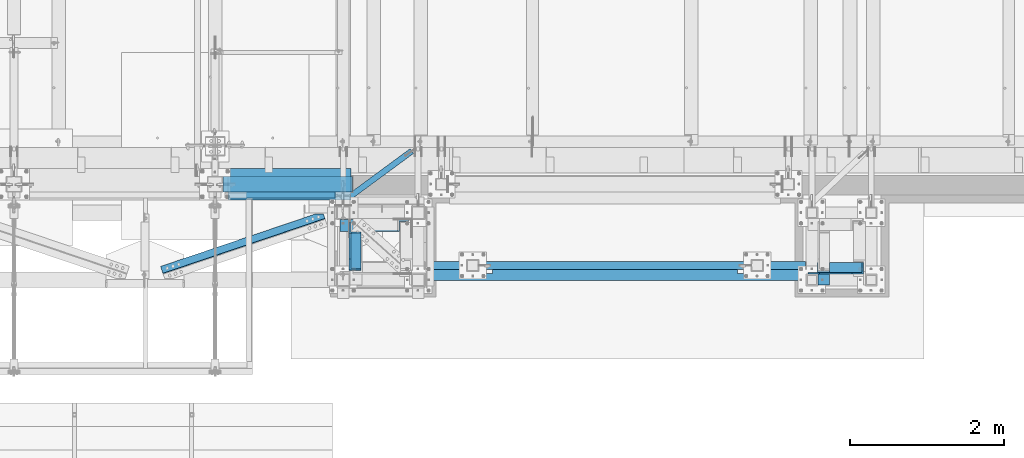
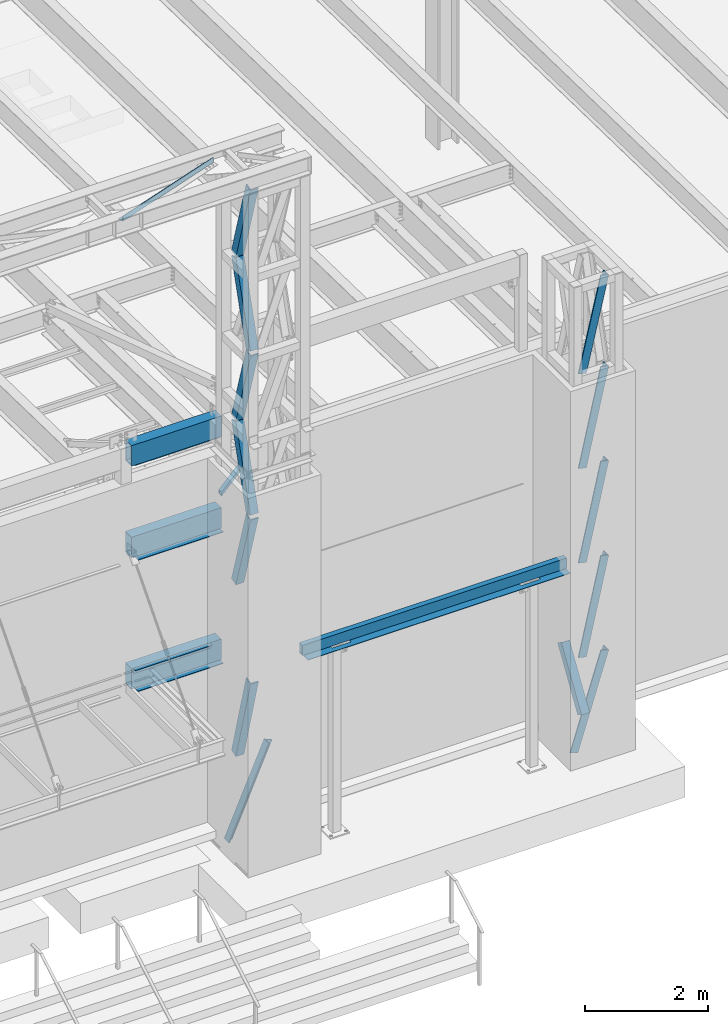
# One storey, part 1062 of 1763: 13 members, 11 beams, 8 elements without a shape of their own.
"""IFC2X3 building model written with IfcOpenShell, lengths in millimetres."""

from ifc_helpers import new_model, si_unit, frame, origin_with_axes, place, context, subcontext, project, spatial, faceted_brep, material, type_object, element, aggregate, save


model = new_model("IFC2X3")

# Units and contexts
model_context = context("Model", 3, precision=1e-05, world=origin_with_axes())
body_context = subcontext(model_context, "Body", "Model", "MODEL_VIEW")
ifc_project = project(units=[si_unit("LENGTHUNIT", "METRE", prefix="MILLI"), si_unit("AREAUNIT", "SQUARE_METRE"), si_unit("VOLUMEUNIT", "CUBIC_METRE"), si_unit("MASSUNIT", "GRAM", prefix="KILO"), si_unit("TIMEUNIT", "SECOND"), si_unit("PLANEANGLEUNIT", "RADIAN"), si_unit("SOLIDANGLEUNIT", "STERADIAN"), si_unit("THERMODYNAMICTEMPERATUREUNIT", "DEGREE_CELSIUS"), si_unit("LUMINOUSINTENSITYUNIT", "LUMEN")], contexts=[model_context])

# Site, building, storey
site_placement = place(None, origin_with_axes())
site = spatial("IfcSite", under=ifc_project, at=site_placement, CompositionType="ELEMENT")
building_placement = place(site_placement, origin_with_axes())
building = spatial("IfcBuilding", under=site, at=building_placement, Name="Undefined", CompositionType="ELEMENT")
storey_placement = place(building_placement, origin_with_axes())
storey = spatial("IfcBuildingStorey", under=building, at=storey_placement, Name="Undefined", CompositionType="ELEMENT", Elevation=0.0)

# Assembly, members
assembly_1_placement = place(storey_placement, origin_with_axes())
assembly_1 = element("IfcElementAssembly", 1, at=assembly_1_placement, inside=storey, Name="FRAME", AssemblyPlace="NOTDEFINED", PredefinedType="RIGID_FRAME")
ifc_material_1 = material(Name="STEEL/A36")
member_type = type_object("IfcMemberType", Name="L6X6X7/8", PredefinedType="NOTDEFINED")
member_1_placement = place(assembly_1_placement, frame((-41487.0960743714, -14799.7440466846, 6945.69763129711), z_axis=(-1.90000006114133e-07, 0.846976442016007, -0.531630423010074), x_axis=(1.18999999498545e-07, -0.53163042301006, -0.846976442016028)))
member_1 = element("IfcMember", 2, at=member_1_placement, type_object=member_type, material=ifc_material_1, Name="V. BRACE", ObjectType="L6X6X7/8", context=body_context, shape_type="Brep", body=[
    faceted_brep([(9.09494701772928e-13, -76.2000000000007, -76.2000000000844), (9.09494701772928e-13, 76.2000000000007, -76.2000000000844), (1228.13053531922, 76.1999999928375, -76.2000000008793), (1228.1305353191, -76.2000000071712, -76.2000000007974), (1.81898940354586e-12, -76.2000000000007, -53.9750000000604), (1.81898940354586e-12, 53.9750000000004, -53.9750000000604), (0.0, 53.9750000000004, 76.2000000000771), (0.0, 76.2000000000007, 76.2000000000771), (1228.13053531911, -76.2000000070693, -53.9750000008135), (1228.13053531921, 53.9749999929481, -53.9750000008862), (1228.13053531927, 53.9749999934866, 76.1999999990185), (1228.13053531929, 76.1999999934924, 76.1999999990057)], [[[0, 1, 2, 3]], [[0, 4, 5, 6, 7, 1]], [[5, 4, 8, 9]], [[6, 5, 9, 10]], [[7, 6, 10, 11]], [[1, 7, 11, 2]], [[10, 9, 8, 3, 2, 11]], [[4, 0, 3, 8]]]),
])
member_2_placement = place(assembly_1_placement, frame((-41043.7895703936, -15300.3943970326, 12588.8749998544), z_axis=(-0.975768660920604, 0.0, 0.218804753982199), x_axis=(-0.218804753982199, 0.0, -0.975768660920604)))
member_2 = element("IfcMember", 3, at=member_2_placement, type_object=member_type, material=ifc_material_1, Name="V. BRACE", ObjectType="L6X6X7/8", context=body_context, shape_type="Brep", body=[
    faceted_brep([(9.09494701772928e-13, 76.2000000000007, -76.2000000000844), (0.0, 76.2000000000007, 76.2000000000771), (1920.5820240066, 76.2000000000007, 76.1999999998516), (1920.58202400652, 76.2000000000007, -76.2000000004628), (0.0, 53.9750000000004, 76.2000000000771), (1920.5820240066, 53.9750000000004, 76.1999999998516), (1.81898940354586e-12, 53.9750000000004, -53.9750000000604), (1920.58202400653, 53.9750000000004, -53.9750000004133), (1.81898940354586e-12, -76.2000000000007, -53.9750000000604), (1920.58202400653, -76.2000000000007, -53.9750000004133), (9.09494701772928e-13, -76.2000000000007, -76.2000000000844), (1920.58202400652, -76.2000000000007, -76.2000000004628)], [[[0, 1, 2, 3]], [[1, 4, 5, 2]], [[4, 6, 7, 5]], [[6, 8, 9, 7]], [[8, 10, 11, 9]], [[10, 0, 3, 11]], [[5, 7, 9, 11, 3, 2]], [[10, 8, 6, 4, 1, 0]]]),
])
member_3_placement = place(assembly_1_placement, frame((-41043.7895703902, -15300.3943970326, 10714.8312498544), z_axis=(-0.975768660920604, 0.0, 0.218804753982199), x_axis=(-0.218804753982199, 0.0, -0.975768660920604)))
member_3 = element("IfcMember", 4, at=member_3_placement, type_object=member_type, material=ifc_material_1, Name="V. BRACE", ObjectType="L6X6X7/8", context=body_context, shape_type="Brep", body=[
    faceted_brep([(9.09494701772928e-13, 76.2000000000007, -76.2000000000844), (0.0, 76.2000000000007, 76.2000000000771), (1920.5820240066, 76.2000000000007, 76.1999999998516), (1920.58202400652, 76.2000000000007, -76.2000000004628), (0.0, 53.9750000000004, 76.2000000000771), (1920.5820240066, 53.9750000000004, 76.1999999998516), (1.81898940354586e-12, 53.9750000000004, -53.9750000000604), (1920.58202400653, 53.9750000000004, -53.9750000004133), (1.81898940354586e-12, -76.2000000000007, -53.9750000000604), (1920.58202400653, -76.2000000000007, -53.9750000004133), (9.09494701772928e-13, -76.2000000000007, -76.2000000000844), (1920.58202400652, -76.2000000000007, -76.2000000004628)], [[[0, 1, 2, 3]], [[1, 4, 5, 2]], [[4, 6, 7, 5]], [[6, 8, 9, 7]], [[8, 10, 11, 9]], [[10, 0, 3, 11]], [[5, 7, 9, 11, 3, 2]], [[10, 8, 6, 4, 1, 0]]]),
])
member_4_placement = place(assembly_1_placement, frame((-41043.6534532062, -15300.3943970326, 14401.8000002035), z_axis=(-0.974137606436103, 0.0, 0.225955579101161), x_axis=(-0.225955579101159, 0.0, -0.974137606436103)))
member_4 = element("IfcMember", 5, at=member_4_placement, type_object=member_type, material=ifc_material_1, Name="V. BRACE", ObjectType="L6X6X7/8", context=body_context, shape_type="Brep", body=[
    faceted_brep([(9.09494701772928e-13, 76.2000000000007, -76.2000000000844), (0.0, 76.2000000000007, 76.2000000000771), (1861.05637242494, 76.2000000000007, 76.1999999891268), (1861.05637242493, 76.2000000000007, -76.2000000105327), (0.0, 53.9750000000004, 76.2000000000771), (1861.05637242494, 53.9750000000004, 76.1999999891268), (1.81898940354586e-12, 53.9750000000004, -53.9750000000604), (1861.05637242493, 53.9750000000004, -53.9750000105851), (1.81898940354586e-12, -76.2000000000007, -53.9750000000604), (1861.05637242493, -76.2000000000007, -53.9750000105851), (9.09494701772928e-13, -76.2000000000007, -76.2000000000844), (1861.05637242493, -76.2000000000007, -76.2000000105327)], [[[0, 1, 2, 3]], [[1, 4, 5, 2]], [[4, 6, 7, 5]], [[6, 8, 9, 7]], [[8, 10, 11, 9]], [[10, 0, 3, 11]], [[5, 7, 9, 11, 3, 2]], [[10, 8, 6, 4, 1, 0]]]),
])
member_5_placement = place(assembly_1_placement, frame((-41043.7895703868, -15300.3943970326, 8840.7874998544), z_axis=(-0.975768660920604, 0.0, 0.218804753982199), x_axis=(-0.218804753982199, 0.0, -0.975768660920604)))
member_5 = element("IfcMember", 6, at=member_5_placement, type_object=member_type, material=ifc_material_1, Name="V. BRACE", ObjectType="L6X6X7/8", context=body_context, shape_type="Brep", body=[
    faceted_brep([(9.09494701772928e-13, 76.2000000000007, -76.2000000000844), (0.0, 76.2000000000007, 76.2000000000771), (1920.5820240066, 76.2000000000007, 76.1999999998516), (1920.58202400652, 76.2000000000007, -76.2000000004628), (0.0, 53.9750000000004, 76.2000000000771), (1920.5820240066, 53.9750000000004, 76.1999999998516), (1.81898940354586e-12, 53.9750000000004, -53.9750000000604), (1920.58202400653, 53.9750000000004, -53.9750000004133), (1.81898940354586e-12, -76.2000000000007, -53.9750000000604), (1920.58202400653, -76.2000000000007, -53.9750000004133), (9.09494701772928e-13, -76.2000000000007, -76.2000000000844), (1920.58202400652, -76.2000000000007, -76.2000000004628)], [[[0, 1, 2, 3]], [[1, 4, 5, 2]], [[4, 6, 7, 5]], [[6, 8, 9, 7]], [[8, 10, 11, 9]], [[10, 0, 3, 11]], [[5, 7, 9, 11, 3, 2]], [[10, 8, 6, 4, 1, 0]]]),
])
member_6_placement = place(assembly_1_placement, frame((-41042.0722853274, -15300.3943970326, 6966.74375009387), z_axis=(-0.953918533796507, 0.0, 0.300065710935991), x_axis=(-0.300065710935989, 0.0, -0.953918533796508)))
member_6 = element("IfcMember", 7, at=member_6_placement, type_object=member_type, material=ifc_material_1, Name="V. BRACE", ObjectType="L6X6X7/8", context=body_context, shape_type="Brep", body=[
    faceted_brep([(9.09494701772928e-13, 76.2000000000007, -76.2000000000844), (0.0, 76.2000000000007, 76.2000000000771), (1927.29114476475, 76.2000000000007, 76.2000000015396), (1927.29114476478, 76.2000000000007, -76.1999999978871), (0.0, 53.9750000000004, 76.2000000000771), (1927.29114476475, 53.9750000000004, 76.2000000015396), (1.81898940354586e-12, 53.9750000000004, -53.9750000000604), (1927.29114476478, 53.9750000000004, -53.974999997954), (1.81898940354586e-12, -76.2000000000007, -53.9750000000604), (1927.29114476478, -76.2000000000007, -53.974999997954), (9.09494701772928e-13, -76.2000000000007, -76.2000000000844), (1927.29114476478, -76.2000000000007, -76.1999999978871)], [[[0, 1, 2, 3]], [[1, 4, 5, 2]], [[4, 6, 7, 5]], [[6, 8, 9, 7]], [[8, 10, 11, 9]], [[10, 0, 3, 11]], [[5, 7, 9, 11, 3, 2]], [[10, 8, 6, 4, 1, 0]]]),
])
aggregate(assembly_1, [member_1, member_2, member_3, member_4, member_5, member_6])

assembly_2_placement = place(storey_placement, origin_with_axes())
assembly_2 = element("IfcElementAssembly", 8, at=assembly_2_placement, inside=storey, Name="FRAME", AssemblyPlace="NOTDEFINED", PredefinedType="RIGID_FRAME")
member_7_placement = place(assembly_2_placement, frame((-47735.5523704055, -14744.7029550285, 5067.29978345798), z_axis=(0.0, -1.0, 0.0), x_axis=(0.400955294202786, 1.00000025355767e-09, 0.916097621463323)))
member_7 = element("IfcMember", 9, at=member_7_placement, type_object=member_type, material=ifc_material_1, Name="V. BRACE", ObjectType="L6X6X7/8", context=body_context, shape_type="Brep", body=[
    faceted_brep([(74.9407141546053, 76.200000000179, -76.2000000000698), (74.9407141245028, 76.1999999999971, 76.1999999999316), (1940.84119258349, 76.2000000036787, 76.1999999991021), (1940.84119258334, 76.2000000038752, -76.2000000008975), (74.9407141244592, 53.9750000000131, 76.1999999999425), (1940.84119258348, 53.9750000036947, 76.1999999991149), (74.9407141501724, 53.9750000001732, -53.9750000000568), (1940.84119258335, 53.9750000038621, -53.9750000008862), (74.9407141499069, -76.1999999997206, -53.9749999999967), (1940.84119258335, -76.199999996039, -53.9750000008244), (74.9407141542943, -76.1999999996842, -76.1999999999953), (1940.84119258333, -76.1999999960099, -76.2000000008247)], [[[0, 1, 2, 3]], [[1, 4, 5, 2]], [[4, 6, 7, 5]], [[6, 8, 9, 7]], [[8, 10, 11, 9]], [[10, 0, 3, 11]], [[5, 7, 9, 11, 3, 2]], [[10, 8, 6, 4, 1, 0]]]),
])
member_8_placement = place(assembly_2_placement, frame((-47583.152204354, -14779.1376538228, 16774.1203120008), z_axis=(1.0, 0.0, 0.0), x_axis=(0.0, -0.28425468487658, 0.958748806583725)))
member_8 = element("IfcMember", 10, at=member_8_placement, type_object=member_type, material=ifc_material_1, Name="V. BRACE", ObjectType="L6X6X7/8", context=body_context, shape_type="Brep", body=[
    faceted_brep([(1.81898940354586e-12, -76.2000000000007, -53.9750000000604), (9.09494701772928e-13, -76.2000000000007, -76.2000000000844), (1668.42939139346, -76.2000000002827, -76.1999999999971), (1668.42939139346, -76.2000000002827, -53.9749999999985), (1.81898940354586e-12, 53.9750000000004, -53.9750000000604), (1668.42939139347, 53.9749999998239, -53.9749999999985), (0.0, 53.9750000000004, 76.2000000000771), (1668.42939139347, 53.9749999998239, 76.1999999999971), (0.0, 76.2000000000007, 76.2000000000771), (1668.42939139347, 76.1999999998425, 76.1999999999971), (9.09494701772928e-13, 76.2000000000007, -76.2000000000844), (1668.42939139347, 76.1999999998425, -76.1999999999971)], [[[0, 1, 2, 3]], [[4, 0, 3, 5]], [[6, 4, 5, 7]], [[8, 6, 7, 9]], [[1, 0, 4, 6, 8, 10]], [[1, 10, 11, 2]], [[7, 5, 3, 2, 11, 9]], [[10, 8, 9, 11]]]),
])
member_9_placement = place(assembly_2_placement, frame((-47583.1519986869, -14778.8696225472, 13524.110936), z_axis=(1.0, 0.0, 0.0), x_axis=(0.0, -0.2898381940609, 0.957075661201097)))
member_9 = element("IfcMember", 11, at=member_9_placement, type_object=member_type, material=ifc_material_1, Name="V. BRACE", ObjectType="L6X6X7/8", context=body_context, shape_type="Brep", body=[
    faceted_brep([(9.09494701772928e-13, 76.2000000000007, -76.2000000000844), (0.0, 76.2000000000007, 76.2000000000771), (1639.83084289621, 76.1999999999971, 76.1999999993677), (1639.83084289615, 76.1999999999971, -76.2000000006465), (0.0, 53.9750000000004, 76.2000000000771), (1639.83084289621, 53.9749999999985, 76.1999999993677), (1.81898940354586e-12, 53.9750000000004, -53.9750000000604), (1639.83084289616, 53.9749999999985, -53.9750000006443), (1.81898940354586e-12, -76.2000000000007, -53.9750000000604), (1639.83084289616, -76.1999999999971, -53.9750000006443), (9.09494701772928e-13, -76.2000000000007, -76.2000000000844), (1639.83084289615, -76.1999999999971, -76.2000000006465)], [[[0, 1, 2, 3]], [[1, 4, 5, 2]], [[4, 6, 7, 5]], [[6, 8, 9, 7]], [[8, 10, 11, 9]], [[10, 0, 3, 11]], [[5, 7, 9, 11, 3, 2]], [[10, 8, 6, 4, 1, 0]]]),
])
member_10_placement = place(assembly_2_placement, frame((-47583.1519986869, -15253.4500546581, 15149.115624), z_axis=(1.0, 0.0, 0.0), x_axis=(0.0, 0.289497082081885, 0.957178896270741)))
member_10 = element("IfcMember", 12, at=member_10_placement, type_object=member_type, material=ifc_material_1, Name="V. BRACE", ObjectType="L6X6X7/8", context=body_context, shape_type="Brep", body=[
    faceted_brep([(9.09494701772928e-13, 76.2000000000007, -76.2000000000844), (0.0, 76.2000000000007, 76.2000000000771), (1639.65398114875, 76.1999999994368, 76.1999999999971), (1639.65398114875, 76.1999999994368, -76.1999999999971), (0.0, 53.9750000000004, 76.2000000000771), (1639.65398114874, 53.9749999994274, 76.1999999999971), (1.81898940354586e-12, 53.9750000000004, -53.9750000000604), (1639.65398114874, 53.9749999994274, -53.9749999999985), (1.81898940354586e-12, -76.2000000000007, -53.9750000000604), (1639.6539811487, -76.2000000006228, -53.9749999999985), (9.09494701772928e-13, -76.2000000000007, -76.2000000000844), (1639.6539811487, -76.2000000006228, -76.1999999999971)], [[[0, 1, 2, 3]], [[1, 4, 5, 2]], [[4, 6, 7, 5]], [[6, 8, 9, 7]], [[8, 10, 11, 9]], [[10, 0, 3, 11]], [[5, 7, 9, 11, 3, 2]], [[10, 8, 6, 4, 1, 0]]]),
])
member_11_placement = place(assembly_2_placement, frame((-47583.4054377434, -14778.8361418315, 10274.101560012), z_axis=(0.999999857834454, 0.000533227035961318, -1.19036485557445e-10), x_axis=(0.000154551999968596, -0.28984251293782, 0.957074340794679)))
member_11 = element("IfcMember", 13, at=member_11_placement, type_object=member_type, material=ifc_material_1, Name="V. BRACE", ObjectType="L6X6X7/8", context=body_context, shape_type="Brep", body=[
    faceted_brep([(9.09494701772928e-13, 76.2000000000007, -76.2000000000844), (0.0, 76.2000000000007, 76.2000000000771), (1639.83084289621, 76.1999999999971, 76.1999999993677), (1639.83084289615, 76.1999999999971, -76.2000000006465), (0.0, 53.9750000000004, 76.2000000000771), (1639.83084289621, 53.9749999999985, 76.1999999993677), (1.81898940354586e-12, 53.9750000000004, -53.9750000000604), (1639.83084289616, 53.9749999999985, -53.9750000006443), (1.81898940354586e-12, -76.2000000000007, -53.9750000000604), (1639.83084289616, -76.1999999999971, -53.9750000006443), (9.09494701772928e-13, -76.2000000000007, -76.2000000000844), (1639.83084289615, -76.1999999999971, -76.2000000006465)], [[[0, 1, 2, 3]], [[1, 4, 5, 2]], [[4, 6, 7, 5]], [[6, 8, 9, 7]], [[8, 10, 11, 9]], [[10, 0, 3, 11]], [[5, 7, 9, 11, 3, 2]], [[10, 8, 6, 4, 1, 0]]]),
])
member_12_placement = place(assembly_2_placement, frame((-47583.1519986869, -15253.4580745193, 11899.106248), z_axis=(1.0, 0.0, 0.0), x_axis=(0.0, 0.289837226101388, 0.957075954334792)))
member_12 = element("IfcMember", 14, at=member_12_placement, type_object=member_type, material=ifc_material_1, Name="V. BRACE", ObjectType="L6X6X7/8", context=body_context, shape_type="Brep", body=[
    faceted_brep([(9.09494701772928e-13, 76.2000000000007, -76.2000000000844), (0.0, 76.2000000000007, 76.2000000000771), (1639.83084289621, 76.1999999999971, 76.1999999993677), (1639.83084289615, 76.1999999999971, -76.2000000006465), (0.0, 53.9750000000004, 76.2000000000771), (1639.83084289621, 53.9749999999985, 76.1999999993677), (1.81898940354586e-12, 53.9750000000004, -53.9750000000604), (1639.83084289616, 53.9749999999985, -53.9750000006443), (1.81898940354586e-12, -76.2000000000007, -53.9750000000604), (1639.83084289616, -76.1999999999971, -53.9750000006443), (9.09494701772928e-13, -76.2000000000007, -76.2000000000844), (1639.83084289615, -76.1999999999971, -76.2000000006465)], [[[0, 1, 2, 3]], [[1, 4, 5, 2]], [[4, 6, 7, 5]], [[6, 8, 9, 7]], [[8, 10, 11, 9]], [[10, 0, 3, 11]], [[5, 7, 9, 11, 3, 2]], [[10, 8, 6, 4, 1, 0]]]),
])
member_13_placement = place(assembly_2_placement, frame((-47583.1519986869, -14779.5096653903, 6870.7000000123), z_axis=(1.0, 0.0, 0.0), x_axis=(0.0, -0.26528391591723, 0.964170339699174)))
member_13 = element("IfcMember", 15, at=member_13_placement, type_object=member_type, material=ifc_material_1, Name="V. BRACE", ObjectType="L6X6X7/8", context=body_context, shape_type="Brep", body=[
    faceted_brep([(9.09494701772928e-13, 76.2000000000007, -76.2000000000844), (0.0, 76.2000000000007, 76.2000000000771), (1786.4452256684, 76.1999999999971, 76.2000000014923), (1786.44522566839, 76.1999999999971, -76.1999999985128), (0.0, 53.9750000000004, 76.2000000000771), (1786.4452256684, 53.9749999999985, 76.2000000014923), (1.81898940354586e-12, 53.9750000000004, -53.9750000000604), (1786.44522566839, 53.9749999999985, -53.9749999985124), (1.81898940354586e-12, -76.2000000000007, -53.9750000000604), (1786.44522566839, -76.1999999999971, -53.9749999985124), (9.09494701772928e-13, -76.2000000000007, -76.2000000000844), (1786.44522566839, -76.1999999999971, -76.1999999985128)], [[[0, 1, 2, 3]], [[1, 4, 5, 2]], [[4, 6, 7, 5]], [[6, 8, 9, 7]], [[8, 10, 11, 9]], [[10, 0, 3, 11]], [[5, 7, 9, 11, 3, 2]], [[10, 8, 6, 4, 1, 0]]]),
])
aggregate(assembly_2, [member_7, member_8, member_9, member_10, member_11, member_12, member_13])

# Assembly, beam
assembly_3_placement = place(storey_placement, origin_with_axes())
assembly_3 = element("IfcElementAssembly", 16, at=assembly_3_placement, inside=storey, Name="BEAM", AssemblyPlace="NOTDEFINED", PredefinedType="RIGID_FRAME")
ifc_material_2 = material()
beam_type_1 = type_object("IfcBeamType", Name="HSS16X8X5/8", PredefinedType="NOTDEFINED")
beam_1_placement = place(assembly_3_placement, frame((-49300.8270083209, -14208.1275869816, 13055.6221257957), z_axis=(0.0, 0.0, 1.0), x_axis=(1.0, 0.0, 0.0)))
beam_1 = element("IfcBeam", 17, at=beam_1_placement, type_object=beam_type_1, material=ifc_material_2, Name="BEAM", ObjectType="HSS16X8X5/8", context=body_context, shape_type="Brep", body=[
    faceted_brep([(0.0, 85.7250000000058, -187.325), (0.0, -85.7250000000058, -187.325), (1682.74960859423, -85.7250000000004, -187.325000000001), (1682.74960859423, 85.7250000000004, -187.325000000001), (0.0, -85.7250000000058, 187.325), (1682.74960859423, -85.7250000000004, 187.325000000001), (0.0, 85.7250000000058, 187.325), (1682.74960859423, 85.7250000000004, 187.325000000001), (0.0, 101.600000000006, -203.2), (0.0, 101.600000000006, 203.2), (1682.74960859423, 101.6, 203.200000000001), (1682.74960859423, 101.6, -203.200000000001), (0.0, -101.600000000006, 203.2), (1682.74960859423, -101.6, 203.200000000001), (0.0, -101.600000000006, -203.2), (1682.74960859423, -101.6, -203.200000000001)], [[[0, 1, 2, 3]], [[1, 4, 5, 2]], [[4, 6, 7, 5]], [[6, 0, 3, 7]], [[8, 9, 10, 11]], [[9, 12, 13, 10]], [[12, 14, 15, 13]], [[14, 8, 11, 15]], [[13, 15, 11, 10], [5, 7, 3, 2]], [[14, 12, 9, 8], [6, 4, 1, 0]]]),
])

assembly_4_placement = place(storey_placement, origin_with_axes())
assembly_4 = element("IfcElementAssembly", 18, at=assembly_4_placement, inside=storey, Name="ANGLE", AssemblyPlace="NOTDEFINED", PredefinedType="RIGID_FRAME")
beam_type_2 = type_object("IfcBeamType", Name="L4X4X1/4", PredefinedType="NOTDEFINED")
beam_2_placement = place(assembly_4_placement, frame((-50331.0000536634, -15404.6097590056, 18672.175), z_axis=(-0.320655214854611, 0.947195984570534, 0.0), x_axis=(0.947195984570534, 0.320655214854612, 0.0)))
beam_2 = element("IfcBeam", 19, at=beam_2_placement, type_object=beam_type_2, material=ifc_material_1, Name="ANGLE", ObjectType="L4X4X1/4", context=body_context, shape_type="Brep", body=[
    faceted_brep([(2473.90666734029, 44.4500000000007, 14.9212591829789), (2473.90666734029, 50.7999999999993, 14.9212591829789), (2368.26819304615, 50.7999999999993, 50.8000000021136), (2368.26819304615, 44.4500000000007, 50.8000000021136), (2473.90322387923, 44.4500000000007, -44.4499999977991), (2473.90322387923, -50.7999999999993, -44.4499999977991), (2473.90284887469, -50.7999999999993, -50.7999999978013), (2473.90284887469, 50.7999999999993, -50.7999999978013), (248.852789269382, 50.7999999999993, -50.7999999997803), (248.852789269382, -50.7999999999993, -50.7999999997803), (248.853157555044, -50.7999999999993, -44.4499999997781), (248.853157555044, 44.4500000000007, -44.4499999997781), (248.858681840073, 44.4500000000007, 50.8000000002273), (248.858681840073, 50.7999999999993, 50.8000000002273)], [[[0, 1, 2, 3]], [[4, 5, 6, 7, 1, 0]], [[8, 9, 10, 11, 12, 13]], [[13, 12, 3, 2]], [[8, 13, 2, 1, 7]], [[9, 8, 7, 6]], [[10, 9, 6, 5]], [[11, 10, 5, 4]], [[12, 11, 4, 0, 3]]]),
])
aggregate(assembly_4, [beam_2])

assembly_5_placement = place(storey_placement, origin_with_axes())
assembly_5 = element("IfcElementAssembly", 20, at=assembly_5_placement, inside=storey, Name="BEAM", AssemblyPlace="NOTDEFINED", PredefinedType="RIGID_FRAME")
beam_type_3 = type_object("IfcBeamType", Name="HSS3X3X1/4", PredefinedType="NOTDEFINED")
beam_3_placement = place(assembly_5_placement, frame((-47735.5523997267, -14433.715917774, 11820.525), z_axis=(0.0, 0.0, 1.0), x_axis=(0.805254059732427, 0.592929927802979, 0.0)))
beam_3 = element("IfcBeam", 21, at=beam_3_placement, type_object=beam_type_3, material=ifc_material_2, Name="BEAM", ObjectType="HSS3X3X1/4", context=body_context, shape_type="Brep", body=[
    faceted_brep([(1107.48844328983, 6.37417618212567, 38.1000000000004), (999.541056084388, 6.39964000033433, 38.1000000000004), (999.541056084388, 6.39964000033433, 31.75), (1107.48844328983, 6.37417618212567, 31.75), (999.53806026862, -6.30035964624039, 38.1000000000004), (999.53806026862, -6.30035964624403, 31.75), (1107.4884432898, -6.32582417114099, 38.1000000000004), (1107.4884432898, -6.32582417114099, 31.75), (1107.48844328983, 6.37417618212567, -31.75), (999.541056084367, 6.39964000033433, -31.75), (999.541056084367, 6.39964000033433, -38.1000000000004), (1107.48844328983, 6.37417618212567, -38.1000000000004), (999.538060268591, -6.30035964624767, -31.75), (999.538060268591, -6.30035964624767, -38.1000000000004), (1107.4884432898, -6.32582417114099, -31.75), (1107.4884432898, -6.32582417114099, -38.1000000000004), (70.6926274011275, 31.7499999998654, 31.75), (70.6926274011275, 31.7499999998654, -31.75), (1107.48844328988, 31.7499999987231, -31.75), (1107.48844328988, 31.7499999987231, 31.75), (1107.48844328976, -31.7500000011605, 31.75), (23.935892727568, -31.7499999999709, 31.75), (23.935892727568, -31.7499999999709, -31.75), (1107.48844328976, -31.7500000011605, -31.75), (19.2602192602208, -38.0999999999585, -38.1000000000004), (19.2602192602208, -38.0999999999585, 38.1000000000004), (75.368300868482, 38.0999999998494, 38.1000000000004), (75.368300868482, 38.0999999998494, -38.1000000000004), (1107.48844328989, 38.0999999987143, 38.1000000000004), (1107.48844328989, 38.0999999987143, -38.1000000000004), (1107.48844328975, -38.1000000011518, -38.1000000000004), (1107.48844328975, -38.1000000011518, 38.1000000000004)], [[[0, 1, 2, 3]], [[4, 5, 2, 1]], [[6, 7, 5, 4]], [[8, 9, 10, 11]], [[12, 13, 10, 9]], [[14, 15, 13, 12]], [[16, 17, 18, 19]], [[20, 21, 16, 19, 3, 2, 5, 7]], [[22, 21, 20, 23]], [[9, 8, 18, 17, 22, 23, 14, 12]], [[24, 25, 26, 27], [16, 21, 22, 17]], [[27, 26, 28, 29]], [[19, 18, 8, 11, 29, 28, 0, 3]], [[30, 24, 27, 29, 11, 10, 13, 15]], [[25, 24, 30, 31]], [[1, 0, 28, 26, 25, 31, 6, 4]], [[31, 30, 15, 14, 23, 20, 7, 6]]]),
])
aggregate(assembly_5, [beam_3])

assembly_6_placement = place(storey_placement, origin_with_axes())
assembly_6 = element("IfcElementAssembly", 22, at=assembly_6_placement, inside=storey, Name="BEAM", AssemblyPlace="NOTDEFINED", PredefinedType="RIGID_FRAME")
beam_type_4 = type_object("IfcBeamType", Name="HSS16X8X1/4", PredefinedType="NOTDEFINED")
beam_4_placement = place(assembly_6_placement, frame((-49300.8270083209, -14208.1275869816, 11239.5), z_axis=(0.0, 0.0, 1.0), x_axis=(1.0, 0.0, 0.0)))
beam_4 = element("IfcBeam", 23, at=beam_4_placement, type_object=beam_type_4, material=ifc_material_2, Name="BEAM", ObjectType="HSS16X8X1/4", context=body_context, shape_type="Brep", body=[
    faceted_brep([(0.0, 95.25, -196.85), (0.0, -95.25, -196.85), (1682.74961290975, -95.25, -196.85), (1682.74961290975, 95.25, -196.85), (0.0, -95.25, 196.85), (1682.74961290975, -95.25, 196.85), (0.0, 95.25, 196.85), (1682.74961290975, 95.25, 196.85), (0.0, 101.600000000006, -203.2), (0.0, 101.600000000006, 203.2), (1682.74960859423, 101.6, 203.200000000001), (1682.74960859423, 101.6, -203.200000000001), (0.0, -101.600000000006, 203.2), (1682.74960859423, -101.6, 203.200000000001), (0.0, -101.600000000006, -203.2), (1682.74960859423, -101.6, -203.200000000001)], [[[0, 1, 2, 3]], [[1, 4, 5, 2]], [[4, 6, 7, 5]], [[6, 0, 3, 7]], [[8, 9, 10, 11]], [[9, 12, 13, 10]], [[12, 14, 15, 13]], [[14, 8, 11, 15]], [[13, 15, 11, 10], [5, 7, 3, 2]], [[14, 12, 9, 8], [6, 4, 1, 0]]]),
])

assembly_7_placement = place(storey_placement, origin_with_axes())
assembly_7 = element("IfcElementAssembly", 24, at=assembly_7_placement, inside=storey, Name="BEAM", AssemblyPlace="NOTDEFINED", PredefinedType="RIGID_FRAME")
beam_5_placement = place(assembly_7_placement, frame((-49300.8270083209, -14208.1275869816, 8636.0), z_axis=(0.0, 0.0, 1.0), x_axis=(1.0, 0.0, 0.0)))
beam_5 = element("IfcBeam", 25, at=beam_5_placement, type_object=beam_type_4, material=ifc_material_2, Name="BEAM", ObjectType="HSS16X8X1/4", context=body_context, shape_type="Brep", body=[
    faceted_brep([(0.0, 95.25, -196.85), (0.0, -95.25, -196.85), (1682.74961290975, -95.25, -196.85), (1682.74961290975, 95.25, -196.85), (0.0, -95.25, 196.85), (1682.74961290975, -95.25, 196.85), (0.0, 95.25, 196.85), (1682.74961290975, 95.25, 196.85), (0.0, 101.600000000006, -203.2), (0.0, 101.600000000006, 203.2), (1682.74960859423, 101.6, 203.200000000001), (1682.74960859423, 101.6, -203.200000000001), (0.0, -101.600000000006, 203.2), (1682.74960859423, -101.6, 203.200000000001), (0.0, -101.600000000006, -203.2), (1682.74960859423, -101.6, -203.200000000001)], [[[0, 1, 2, 3]], [[1, 4, 5, 2]], [[4, 6, 7, 5]], [[6, 0, 3, 7]], [[8, 9, 10, 11]], [[9, 12, 13, 10]], [[12, 14, 15, 13]], [[14, 8, 11, 15]], [[13, 15, 11, 10], [5, 7, 3, 2]], [[14, 12, 9, 8], [6, 4, 1, 0]]]),
])

assembly_8_placement = place(storey_placement, origin_with_axes())
assembly_8 = element("IfcElementAssembly", 26, at=assembly_8_placement, inside=storey, Name="BEAM", AssemblyPlace="NOTDEFINED", PredefinedType="RIGID_FRAME")
beam_type_5 = type_object("IfcBeamType", PredefinedType="NOTDEFINED")
beam_6_placement = place(assembly_8_placement, frame((-46659.237129112, -15351.1250613784, 8783.6375), z_axis=(0.0, 1.0, 0.0), x_axis=(1.0, 0.0, 0.0)))
beam_6 = element("IfcBeam", 27, at=beam_6_placement, type_object=beam_type_5, material=ifc_material_1, Name="PLATE", context=body_context, shape_type="Brep", body=[
    faceted_brep([(4054.47363319391, -4.76249999999891, 111.125), (4054.47363319391, -4.76250000000073, -15.8750000000055), (4054.47363319391, 4.76250000000073, -15.8750000000055), (4054.47363319391, 4.76250000000073, 111.125), (4410.07363319392, -4.76250000000073, -15.8750000000055), (4410.07363319392, 4.76250000000073, -15.8750000000055), (4410.07363319392, -4.76250000000073, 111.125), (4410.07363319392, 4.76250000000073, 111.125), (863.600000381426, -4.76249999999709, 111.125), (863.600000381426, 4.76250000000073, 111.125), (863.600000381426, 4.76250000000073, -15.8750000000109), (863.600000381426, -4.76249999999709, -15.8750000000109), (508.00000038142, 4.76250000000073, -15.8750000000109), (508.00000038142, -4.76249999999709, -15.8750000000109), (508.00000038142, -4.76250000000073, 111.125), (508.00000038142, 4.76250000000073, 111.125), (0.0, 4.76250000000073, 111.125), (0.0, -4.76250000000073, 111.125), (0.0, -4.76250000000073, -111.125), (0.0, 4.76250000000073, -111.125), (4918.08389902732, 4.76250000000073, -111.125), (4918.08389902732, -4.76250000000073, -111.125), (4918.08389902732, -4.76250000000073, 111.125), (4918.08389902732, 4.76250000000073, 111.125)], [[[0, 1, 2, 3]], [[4, 5, 2, 1]], [[6, 7, 5, 4]], [[8, 9, 10, 11]], [[11, 10, 12, 13]], [[14, 13, 12, 15]], [[16, 17, 14, 15]], [[18, 17, 16, 19]], [[18, 19, 20, 21]], [[22, 21, 20, 23]], [[1, 0, 8, 11, 13, 14, 17, 18, 21, 22, 6, 4]], [[9, 8, 0, 3]], [[23, 20, 19, 16, 15, 12, 10, 9, 3, 2, 5, 7]], [[22, 23, 7, 6]]]),
])

# Beam
beam_type_6 = type_object("IfcBeamType", Name="L4X3X3/8", PredefinedType="NOTDEFINED")
beam_7_placement = place(assembly_7_placement, frame((-47840.3274007641, -14347.8275675222, 8788.4), z_axis=(0.0, 0.0, -1.0), x_axis=(-1.0, 0.0, 0.0)))
beam_7 = element("IfcBeam", 28, at=beam_7_placement, type_object=beam_type_6, material=ifc_material_1, Name="ANGLE", ObjectType="L4X3X3/8", context=body_context, shape_type="Brep", body=[
    faceted_brep([(1.45519152283669e-10, 38.0999999999985, -50.7999999999993), (1.45519152283669e-10, 38.0999999999985, 50.7999999999993), (1435.09955556523, 38.1000000012118, 50.7999999999993), (1435.09955556523, 38.1000000012118, -50.7999999999993), (1.09139364212751e-10, 28.5749999999989, 50.7999999999993), (1435.09955556526, 28.5750000012122, 50.7999999999993), (1.09139364212751e-10, 28.5749999999989, -41.2749999999996), (1435.09955556526, 28.5750000012122, -41.2749999999996), (-1.23691279441118e-10, -38.1000000000022, -41.2749999999996), (1435.09955556544, -38.0999999987871, -41.2749999999996), (-1.23691279441118e-10, -38.1000000000022, -50.7999999999993), (1435.09955556544, -38.0999999987871, -50.7999999999993)], [[[0, 1, 2, 3]], [[1, 4, 5, 2]], [[4, 6, 7, 5]], [[6, 8, 9, 7]], [[8, 10, 11, 9]], [[10, 0, 3, 11]], [[5, 7, 9, 11, 3, 2]], [[10, 8, 6, 4, 1, 0]]]),
])

beam_type_7 = type_object("IfcBeamType", Name="HSS8X4X3/8", PredefinedType="NOTDEFINED")
beam_8_placement = place(assembly_8_placement, frame((-46684.6371287306, -15265.4000613784, 8890.0), z_axis=(0.0, 0.0, 1.0), x_axis=(1.0, 0.0, 0.0)))
beam_8 = element("IfcBeam", 29, at=beam_8_placement, type_object=beam_type_7, material=ifc_material_2, Name="BEAM", ObjectType="HSS8X4X3/8", context=body_context, shape_type="Brep", body=[
    faceted_brep([(6.3500000000131, 41.2749999999996, -92.0750000000007), (6.3500000000131, -41.2749999999996, -92.0750000000007), (4962.53389826443, -41.2749999999996, -92.0750000000007), (4962.53389826443, 41.2749999999996, -92.0750000000007), (6.3500000000131, -41.2749999999996, 92.0750000000007), (4962.53389826443, -41.2749999999996, 92.0750000000007), (6.3500000000131, 41.2749999999996, 92.0750000000007), (4962.53389826443, 41.2749999999996, 92.0750000000007), (6.3500000000131, 50.7999999999993, -101.6), (6.3500000000131, 50.7999999999993, 101.6), (4962.53389826443, 50.7999999999993, 101.6), (4962.53389826443, 50.7999999999993, -101.6), (6.3500000000131, -50.7999999999993, 101.6), (4962.53389826443, -50.7999999999993, 101.6), (6.3500000000131, -50.7999999999993, -101.6), (4962.53389826443, -50.7999999999993, -101.6)], [[[0, 1, 2, 3]], [[1, 4, 5, 2]], [[4, 6, 7, 5]], [[6, 0, 3, 7]], [[8, 9, 10, 11]], [[9, 12, 13, 10]], [[12, 14, 15, 13]], [[14, 8, 11, 15]], [[13, 15, 11, 10], [5, 7, 3, 2]], [[14, 12, 9, 8], [6, 4, 1, 0]]]),
])

aggregate(assembly_8, [beam_6, beam_8])

beam_type_8 = type_object("IfcBeamType", PredefinedType="NOTDEFINED")
beam_9_placement = place(assembly_3_placement, frame((-49237.3283714654, -14157.327586982, 12846.0721257958), z_axis=(0.0, 1.0, 0.0), x_axis=(0.999999999994883, 4.99999977045952e-09, -3.19899999977773e-06)))
beam_9 = element("IfcBeam", 30, at=beam_9_placement, type_object=beam_type_8, material=ifc_material_1, Name="PLATE", context=body_context, shape_type="Brep", body=[
    faceted_brep([(-2.11002770811319e-10, 6.34999999999854, -152.4), (2.25554686039686e-10, 6.34999999999854, 152.4), (1600.19961255685, 6.35000000043874, 152.400000000644), (1600.19961255642, 6.35000000043874, -152.399999999356), (2.11002770811319e-10, -6.34999999999854, 152.399999999998), (1600.19961255683, -6.34999999955653, 152.400000000642), (-2.25554686039686e-10, -6.34999999999854, -152.400000000001), (1600.1996125564, -6.34999999955653, -152.399999999358)], [[[0, 1, 2, 3]], [[1, 4, 5, 2]], [[4, 6, 7, 5]], [[6, 0, 3, 7]], [[5, 7, 3, 2]], [[6, 4, 1, 0]]]),
])

aggregate(assembly_3, [beam_9, beam_1])

beam_10_placement = place(assembly_6_placement, frame((-49237.3270082574, -14258.9275603222, 11029.95), z_axis=(0.0, 1.0, 0.0), x_axis=(1.0, 0.0, 0.0)))
beam_10 = element("IfcBeam", 31, at=beam_10_placement, type_object=beam_type_8, material=ifc_material_1, Name="PLATE", context=body_context, shape_type="Brep", body=[
    faceted_brep([(-2.11002770811319e-10, 6.34999999999854, -152.4), (2.25554686039686e-10, 6.34999999999854, 152.4), (1600.19961255685, 6.35000000043874, 152.400000000644), (1600.19961255642, 6.35000000043874, -152.399999999356), (2.11002770811319e-10, -6.34999999999854, 152.399999999998), (1600.19961255683, -6.34999999955653, 152.400000000642), (-2.25554686039686e-10, -6.34999999999854, -152.400000000001), (1600.1996125564, -6.34999999955653, -152.399999999358)], [[[0, 1, 2, 3]], [[1, 4, 5, 2]], [[4, 6, 7, 5]], [[6, 0, 3, 7]], [[5, 7, 3, 2]], [[6, 4, 1, 0]]]),
])

aggregate(assembly_6, [beam_10, beam_4])

beam_11_placement = place(assembly_7_placement, frame((-49237.3270082574, -14258.9275603222, 8426.45), z_axis=(0.0, 1.0, 0.0), x_axis=(1.0, 0.0, 0.0)))
beam_11 = element("IfcBeam", 32, at=beam_11_placement, type_object=beam_type_8, material=ifc_material_1, Name="PLATE", context=body_context, shape_type="Brep", body=[
    faceted_brep([(-2.11002770811319e-10, 6.34999999999854, -152.4), (2.25554686039686e-10, 6.34999999999854, 152.4), (1600.19961255685, 6.35000000043874, 152.400000000644), (1600.19961255642, 6.35000000043874, -152.399999999356), (2.11002770811319e-10, -6.34999999999854, 152.399999999998), (1600.19961255683, -6.34999999955653, 152.400000000642), (-2.25554686039686e-10, -6.34999999999854, -152.400000000001), (1600.1996125564, -6.34999999955653, -152.399999999358)], [[[0, 1, 2, 3]], [[1, 4, 5, 2]], [[4, 6, 7, 5]], [[6, 0, 3, 7]], [[5, 7, 3, 2]], [[6, 4, 1, 0]]]),
])

aggregate(assembly_7, [beam_7, beam_11, beam_5])

save(model, "model.ifc")
